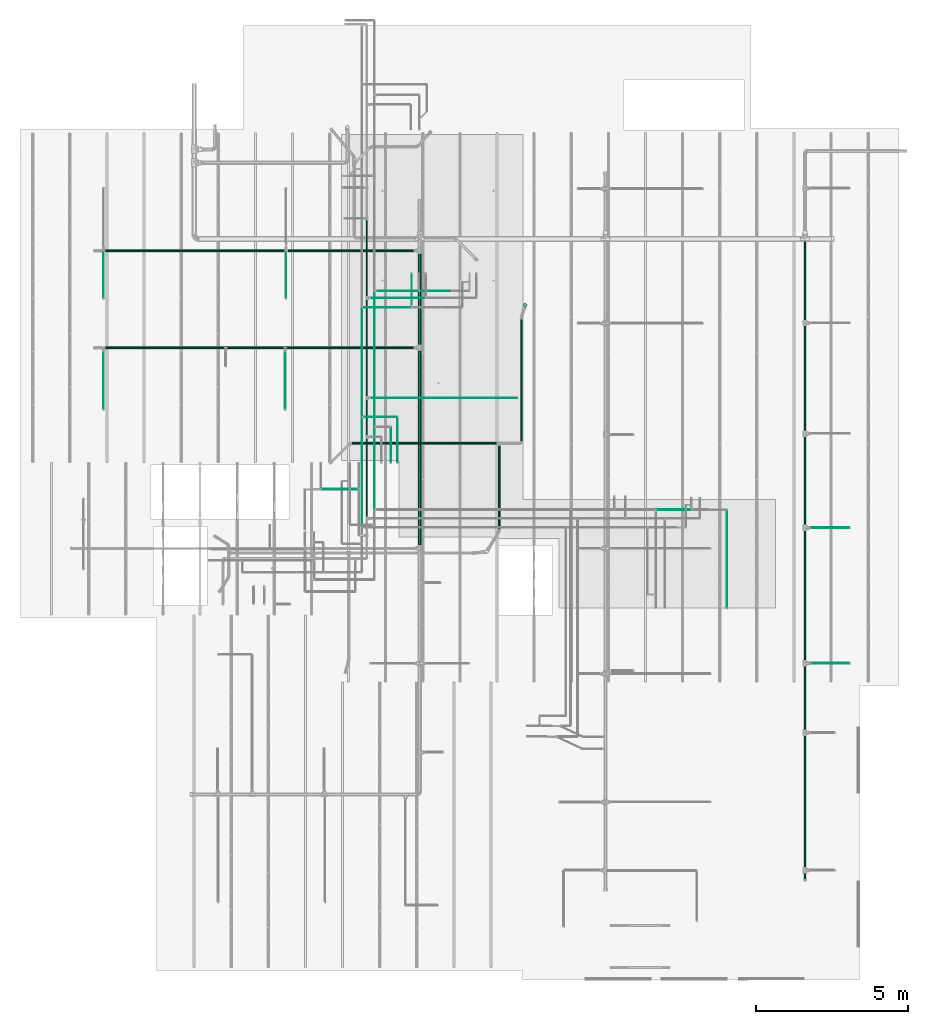
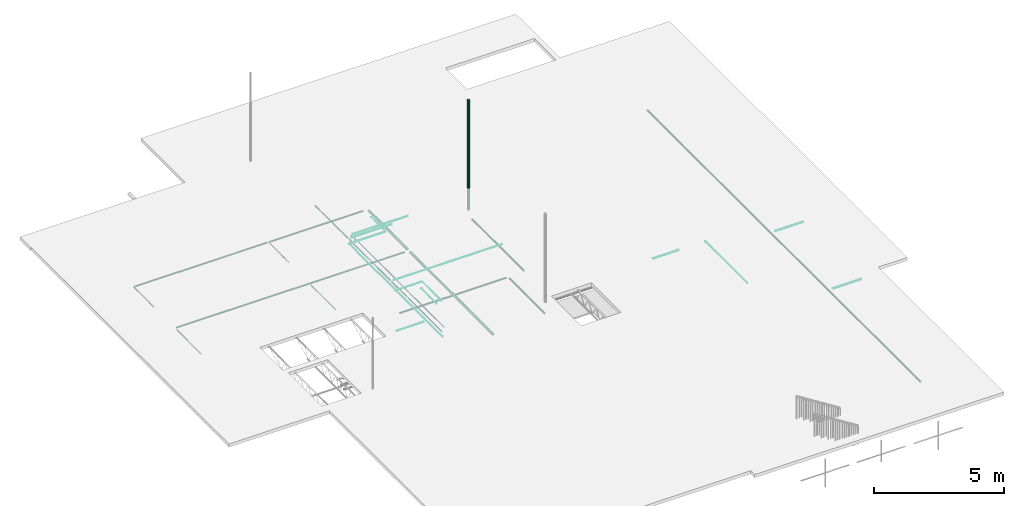
# One storey, part 5 of 173: 36 flow segments.
"""IFC2X3 building model written with IfcOpenShell, lengths in feet."""

from ifc_helpers import new_model, entity, si_unit, converted_unit, derived_unit, direction, frame, origin, origin_2d_with_axis, place, context, subcontext, project, spatial, circle, extrude, source, transform, mapped, type_object, type_shapes, element, save


model = new_model("IFC2X3")

# Units and contexts
model_context = context("Model", 3, precision=0.0001, world=origin(), true_north=direction((6.12303176911189e-17, 1.0)))
body_context = subcontext(model_context, "Body", "Model", "MODEL_VIEW")
ifc_project = project(units=[converted_unit("LENGTHUNIT", "FOOT", entity("IfcRatioMeasure", 0.3048), si_unit("LENGTHUNIT", "METRE"), dimensions=[1, 0, 0, 0, 0, 0, 0]), converted_unit("AREAUNIT", "SQUARE FOOT", entity("IfcRatioMeasure", 0.09290304), si_unit("AREAUNIT", "SQUARE_METRE"), dimensions=[2, 0, 0, 0, 0, 0, 0]), converted_unit("VOLUMEUNIT", "CUBIC FOOT", entity("IfcRatioMeasure", 0.028316846592), si_unit("VOLUMEUNIT", "CUBIC_METRE"), dimensions=[3, 0, 0, 0, 0, 0, 0]), converted_unit("PLANEANGLEUNIT", "DEGREE", entity("IfcRatioMeasure", 0.0174532925199433), si_unit("PLANEANGLEUNIT", "RADIAN"), dimensions=[0, 0, 0, 0, 0, 0, 0]), si_unit("MASSUNIT", "GRAM", prefix="KILO"), derived_unit("MASSDENSITYUNIT", [(si_unit("MASSUNIT", "GRAM", prefix="KILO"), 1), (si_unit("LENGTHUNIT", "METRE"), -3)]), si_unit("TIMEUNIT", "SECOND"), si_unit("FREQUENCYUNIT", "HERTZ"), si_unit("THERMODYNAMICTEMPERATUREUNIT", "DEGREE_CELSIUS"), derived_unit("THERMALTRANSMITTANCEUNIT", [(si_unit("MASSUNIT", "GRAM", prefix="KILO"), 1), (si_unit("THERMODYNAMICTEMPERATUREUNIT", "KELVIN"), -1), (si_unit("TIMEUNIT", "SECOND"), -3)]), derived_unit("VOLUMETRICFLOWRATEUNIT", [(si_unit("LENGTHUNIT", "METRE"), 3), (si_unit("TIMEUNIT", "SECOND"), -1)]), si_unit("ELECTRICCURRENTUNIT", "AMPERE"), si_unit("ELECTRICVOLTAGEUNIT", "VOLT"), si_unit("POWERUNIT", "WATT"), si_unit("FORCEUNIT", "NEWTON"), si_unit("ILLUMINANCEUNIT", "LUX"), si_unit("LUMINOUSFLUXUNIT", "LUMEN"), si_unit("LUMINOUSINTENSITYUNIT", "CANDELA"), derived_unit("USERDEFINED", [(si_unit("MASSUNIT", "GRAM", prefix="KILO"), -1), (si_unit("LENGTHUNIT", "METRE"), -2), (si_unit("TIMEUNIT", "SECOND"), 3), (si_unit("LUMINOUSFLUXUNIT", "LUMEN"), 1)]), derived_unit("LINEARVELOCITYUNIT", [(si_unit("LENGTHUNIT", "METRE"), 1), (si_unit("TIMEUNIT", "SECOND"), -1)]), si_unit("PRESSUREUNIT", "PASCAL"), derived_unit("USERDEFINED", [(si_unit("LENGTHUNIT", "METRE"), -2), (si_unit("MASSUNIT", "GRAM", prefix="KILO"), 1), (si_unit("TIMEUNIT", "SECOND"), -2)])], contexts=[model_context])

# Site, building, storey
site_placement = place(None, origin())
site = spatial("IfcSite", under=ifc_project, at=site_placement, CompositionType="ELEMENT")
building_placement = place(site_placement, origin())
building = spatial("IfcBuilding", under=site, at=building_placement, CompositionType="ELEMENT")
storey_placement = place(building_placement, frame((0.0, 0.0, 8.0)))
storey = spatial("IfcBuildingStorey", under=building, at=storey_placement, Name="REF", CompositionType="ELEMENT", Elevation=8.0)

# Flow segments
pipe_segment_type_1 = type_object("IfcPipeSegmentType", Name="Pipe Types:Standard", PredefinedType="NOTDEFINED")
shared_shape_1 = source(origin(), body_context, "Body", "SweptSolid", [
    extrude(circle(Radius=0.171875, at=origin_2d_with_axis()), frame((14.7453209336625, 35.3918659870249, 9.92847256397639)), (0.0, 0.0, 1.0), 16.9888451443569),
])
type_shapes(pipe_segment_type_1, [shared_shape_1])
flow_segment_1_placement = place(storey_placement, frame((0.0, 0.0, -8.0)))
element("IfcFlowSegment", 1, at=flow_segment_1_placement, inside=storey, type_object=pipe_segment_type_1, Name="Pipe Types:Standard:Standard : Pipe Types:Standard", ObjectType="Standard : Pipe Types:Standard", context=body_context, shape_type="MappedRepresentation", body=[
    mapped(shared_shape_1, transform((0.0, 0.0, 0.0), scale=1.0)),
])
pipe_segment_type_2 = type_object("IfcPipeSegmentType", Name="Pipe Types:Standard", PredefinedType="NOTDEFINED")
shared_shape_2 = source(origin(), body_context, "Body", "SweptSolid", [
    extrude(circle(Radius=0.130208333333333, at=origin_2d_with_axis()), frame((44.8963306532551, -26.4967650842793, 10.4173177083333), z_axis=(0.0, 1.0, 0.0), x_axis=(1.0, 0.0, 0.0)), (0.0, 0.0, 1.0), 69.0),
])
type_shapes(pipe_segment_type_2, [shared_shape_2])
flow_segment_2_placement = place(storey_placement, frame((0.0, 0.0, -8.0)))
element("IfcFlowSegment", 2, at=flow_segment_2_placement, inside=storey, type_object=pipe_segment_type_2, Name="Pipe Types:Standard:Standard : Pipe Types:Standard", ObjectType="Standard : Pipe Types:Standard", context=body_context, shape_type="MappedRepresentation", body=[
    mapped(shared_shape_2, transform((0.0, 0.0, 0.0), scale=1.0)),
])
pipe_segment_type_3 = type_object("IfcPipeSegmentType", Name="Pipe Types:Standard", PredefinedType="NOTDEFINED")
shared_shape_3 = source(origin(), body_context, "Body", "SweptSolid", [
    extrude(circle(Radius=0.171875, at=origin_2d_with_axis()), frame((3.39633065325509, 31.1275034224548, 10.4173177083333), z_axis=(0.0, 1.0, 0.0), x_axis=(1.0, 0.0, 0.0)), (0.0, 0.0, 1.0), 9.77310465993581),
])
type_shapes(pipe_segment_type_3, [shared_shape_3])
flow_segment_3_placement = place(storey_placement, frame((0.0, 0.0, -8.0)))
element("IfcFlowSegment", 3, at=flow_segment_3_placement, inside=storey, type_object=pipe_segment_type_3, Name="Pipe Types:Standard:Standard : Pipe Types:Standard", ObjectType="Standard : Pipe Types:Standard", context=body_context, shape_type="MappedRepresentation", body=[
    mapped(shared_shape_3, transform((0.0, 0.0, 0.0), scale=1.0)),
])
pipe_segment_type_4 = type_object("IfcPipeSegmentType", Name="Pipe Types:Standard", PredefinedType="NOTDEFINED")
shared_shape_4 = source(origin(), body_context, "Body", "SweptSolid", [
    extrude(circle(Radius=0.171875, at=origin_2d_with_axis()), frame((3.39633065325509, 9.51941246670513, 10.4173177083333), z_axis=(0.0, 1.0, 0.0), x_axis=(1.0, 0.0, 0.0)), (0.0, 0.0, 1.0), 20.9191145777969),
])
type_shapes(pipe_segment_type_4, [shared_shape_4])
flow_segment_4_placement = place(storey_placement, frame((0.0, 0.0, -8.0)))
element("IfcFlowSegment", 4, at=flow_segment_4_placement, inside=storey, type_object=pipe_segment_type_4, Name="Pipe Types:Standard:Standard : Pipe Types:Standard", ObjectType="Standard : Pipe Types:Standard", context=body_context, shape_type="MappedRepresentation", body=[
    mapped(shared_shape_4, transform((0.0, 0.0, 0.0), scale=1.0)),
])
pipe_segment_type_5 = type_object("IfcPipeSegmentType", Name="Pipe Types:Standard", PredefinedType="NOTDEFINED")
shared_shape_5 = source(origin(), body_context, "Body", "SweptSolid", [
    extrude(circle(Radius=0.0885416666666667, at=origin_2d_with_axis()), frame((-30.4718603108799, 41.245096271367, 10.4173177083333), z_axis=(1.0, 0.0, 0.0), x_axis=(0.0, 1.0, 0.0)), (0.0, 0.0, 1.0), 19.2467191601049),
])
type_shapes(pipe_segment_type_5, [shared_shape_5])
flow_segment_5_placement = place(storey_placement, frame((0.0, 0.0, -8.0)))
element("IfcFlowSegment", 5, at=flow_segment_5_placement, inside=storey, type_object=pipe_segment_type_5, Name="Pipe Types:Standard:Standard : Pipe Types:Standard", ObjectType="Standard : Pipe Types:Standard", context=body_context, shape_type="MappedRepresentation", body=[
    mapped(shared_shape_5, transform((0.0, 0.0, 0.0), scale=1.0)),
])
pipe_segment_type_6 = type_object("IfcPipeSegmentType", Name="Pipe Types:Standard", PredefinedType="NOTDEFINED")
shared_shape_6 = source(origin(), body_context, "Body", "SweptSolid", [
    extrude(circle(Radius=0.046875, at=origin_2d_with_axis()), frame((-30.6818340641608, 36.1604506020755, 10.4173177083333), z_axis=(0.0, 1.0, 0.0), x_axis=(-1.0, 0.0, 0.0)), (0.0, 0.0, 1.0), 5.08464566929136),
])
type_shapes(pipe_segment_type_6, [shared_shape_6])
flow_segment_6_placement = place(storey_placement, frame((0.0, 0.0, -8.0)))
element("IfcFlowSegment", 6, at=flow_segment_6_placement, inside=storey, type_object=pipe_segment_type_6, Name="Pipe Types:Standard:Standard : Pipe Types:Standard", ObjectType="Standard : Pipe Types:Standard", context=body_context, shape_type="MappedRepresentation", body=[
    mapped(shared_shape_6, transform((0.0, 0.0, 0.0), scale=1.0)),
])
pipe_segment_type_7 = type_object("IfcPipeSegmentType", Name="Pipe Types:Standard", PredefinedType="NOTDEFINED")
shared_shape_7 = source(origin(), body_context, "Body", "SweptSolid", [
    extrude(circle(Radius=0.0885416666666667, at=origin_2d_with_axis()), frame((-10.8051936442133, 41.245096271367, 10.4173177083333), z_axis=(1.0, 0.0, 0.0), x_axis=(0.0, 1.0, 0.0)), (0.0, 0.0, 1.0), 13.5223904392007),
])
type_shapes(pipe_segment_type_7, [shared_shape_7])
flow_segment_7_placement = place(storey_placement, frame((0.0, 0.0, -8.0)))
element("IfcFlowSegment", 7, at=flow_segment_7_placement, inside=storey, type_object=pipe_segment_type_7, Name="Pipe Types:Standard:Standard : Pipe Types:Standard", ObjectType="Standard : Pipe Types:Standard", context=body_context, shape_type="MappedRepresentation", body=[
    mapped(shared_shape_7, transform((0.0, 0.0, 0.0), scale=1.0)),
])
pipe_segment_type_8 = type_object("IfcPipeSegmentType", Name="Pipe Types:Standard", PredefinedType="NOTDEFINED")
shared_shape_8 = source(origin(), body_context, "Body", "SweptSolid", [
    extrude(circle(Radius=0.046875, at=origin_2d_with_axis()), frame((-11.0151673974942, 36.1604506020755, 10.4173177083333), z_axis=(0.0, 1.0, 0.0), x_axis=(-1.0, 0.0, 0.0)), (0.0, 0.0, 1.0), 5.08464566929136),
])
type_shapes(pipe_segment_type_8, [shared_shape_8])
flow_segment_8_placement = place(storey_placement, frame((0.0, 0.0, -8.0)))
element("IfcFlowSegment", 8, at=flow_segment_8_placement, inside=storey, type_object=pipe_segment_type_8, Name="Pipe Types:Standard:Standard : Pipe Types:Standard", ObjectType="Standard : Pipe Types:Standard", context=body_context, shape_type="MappedRepresentation", body=[
    mapped(shared_shape_8, transform((0.0, 0.0, 0.0), scale=1.0)),
])
pipe_segment_type_9 = type_object("IfcPipeSegmentType", Name="Pipe Types:Standard", PredefinedType="NOTDEFINED")
shared_shape_9 = source(origin(), body_context, "Body", "SweptSolid", [
    extrude(circle(Radius=0.046875, at=origin_2d_with_axis()), frame((-30.6818340641608, 24.1983695641872, 10.4173177083333), z_axis=(0.0, 1.0, 0.0), x_axis=(-1.0, 0.0, 0.0)), (0.0, 0.0, 1.0), 6.12532808398936),
])
type_shapes(pipe_segment_type_9, [shared_shape_9])
flow_segment_9_placement = place(storey_placement, frame((0.0, 0.0, -8.0)))
element("IfcFlowSegment", 9, at=flow_segment_9_placement, inside=storey, type_object=pipe_segment_type_9, Name="Pipe Types:Standard:Standard : Pipe Types:Standard", ObjectType="Standard : Pipe Types:Standard", context=body_context, shape_type="MappedRepresentation", body=[
    mapped(shared_shape_9, transform((0.0, 0.0, 0.0), scale=1.0)),
])
pipe_segment_type_10 = type_object("IfcPipeSegmentType", Name="Pipe Types:Standard", PredefinedType="NOTDEFINED")
shared_shape_10 = source(origin(), body_context, "Body", "SweptSolid", [
    extrude(circle(Radius=0.0885416666666667, at=origin_2d_with_axis()), frame((-30.47186031088, 30.7830152334784, 10.4173177083333), z_axis=(1.0, 0.0, 0.0), x_axis=(0.0, 1.0, 0.0)), (0.0, 0.0, 1.0), 33.1890571058673),
])
type_shapes(pipe_segment_type_10, [shared_shape_10])
flow_segment_10_placement = place(storey_placement, frame((0.0, 0.0, -8.0)))
element("IfcFlowSegment", 10, at=flow_segment_10_placement, inside=storey, type_object=pipe_segment_type_10, Name="Pipe Types:Standard:Standard : Pipe Types:Standard", ObjectType="Standard : Pipe Types:Standard", context=body_context, shape_type="MappedRepresentation", body=[
    mapped(shared_shape_10, transform((0.0, 0.0, 0.0), scale=1.0)),
])
pipe_segment_type_11 = type_object("IfcPipeSegmentType", Name="Pipe Types:Standard", PredefinedType="NOTDEFINED")
shared_shape_11 = source(origin(), body_context, "Body", "SweptSolid", [
    extrude(circle(Radius=0.046875, at=origin_2d_with_axis()), frame((-11.0985007308275, 24.1983695641871, 10.4173177083333), z_axis=(0.0, 1.0, 0.0), x_axis=(-1.0, 0.0, 0.0)), (0.0, 0.0, 1.0), 6.12532808398936),
])
type_shapes(pipe_segment_type_11, [shared_shape_11])
flow_segment_11_placement = place(storey_placement, frame((0.0, 0.0, -8.0)))
element("IfcFlowSegment", 11, at=flow_segment_11_placement, inside=storey, type_object=pipe_segment_type_11, Name="Pipe Types:Standard:Standard : Pipe Types:Standard", ObjectType="Standard : Pipe Types:Standard", context=body_context, shape_type="MappedRepresentation", body=[
    mapped(shared_shape_11, transform((0.0, 0.0, 0.0), scale=1.0)),
])
pipe_segment_type_12 = type_object("IfcPipeSegmentType", Name="Pipe Types:Standard", PredefinedType="NOTDEFINED")
shared_shape_12 = source(origin(), body_context, "Body", "SweptSolid", [
    extrude(circle(Radius=0.046875, at=origin_2d_with_axis()), frame((45.5754645115229, 11.3758538235385, 10.4173177083333), z_axis=(1.0, 0.0, 0.0), x_axis=(0.0, -1.0, 0.0)), (0.0, 0.0, 1.0), 4.07217847769013),
])
type_shapes(pipe_segment_type_12, [shared_shape_12])
flow_segment_12_placement = place(storey_placement, frame((0.0, 0.0, -8.0)))
element("IfcFlowSegment", 12, at=flow_segment_12_placement, inside=storey, type_object=pipe_segment_type_12, Name="Pipe Types:Standard:Standard : Pipe Types:Standard", ObjectType="Standard : Pipe Types:Standard", context=body_context, shape_type="MappedRepresentation", body=[
    mapped(shared_shape_12, transform((0.0, 0.0, 0.0), scale=1.0)),
])
pipe_segment_type_13 = type_object("IfcPipeSegmentType", Name="Pipe Types:Standard", PredefinedType="NOTDEFINED")
shared_shape_13 = source(origin(), body_context, "Body", "SweptSolid", [
    extrude(circle(Radius=0.046875, at=origin_2d_with_axis()), frame((45.5754645115229, -3.20747950979483, 10.4173177083333), z_axis=(1.0, 0.0, 0.0), x_axis=(0.0, -1.0, 0.0)), (0.0, 0.0, 1.0), 4.07217847769013),
])
type_shapes(pipe_segment_type_13, [shared_shape_13])
flow_segment_13_placement = place(storey_placement, frame((0.0, 0.0, -8.0)))
element("IfcFlowSegment", 13, at=flow_segment_13_placement, inside=storey, type_object=pipe_segment_type_13, Name="Pipe Types:Standard:Standard : Pipe Types:Standard", ObjectType="Standard : Pipe Types:Standard", context=body_context, shape_type="MappedRepresentation", body=[
    mapped(shared_shape_13, transform((0.0, 0.0, 0.0), scale=1.0)),
])
pipe_segment_type_14 = type_object("IfcPipeSegmentType", Name="Pipe Types:Standard", PredefinedType="NOTDEFINED")
shared_shape_14 = source(origin(), body_context, "Body", "SweptSolid", [
    extrude(circle(Radius=0.0364583333333333, at=origin_2d_with_axis()), frame((-7.15993743672555, 15.5374164738886, 11.0), z_axis=(1.0, 0.0, 0.0), x_axis=(0.0, 1.0, 0.0)), (0.0, 0.0, 1.0), 3.91914996984618),
])
type_shapes(pipe_segment_type_14, [shared_shape_14])
flow_segment_14_placement = place(storey_placement, frame((0.0, 0.0, -8.0)))
element("IfcFlowSegment", 14, at=flow_segment_14_placement, inside=storey, type_object=pipe_segment_type_14, Name="Pipe Types:Standard:Standard : Pipe Types:Standard", ObjectType="Standard : Pipe Types:Standard", context=body_context, shape_type="MappedRepresentation", body=[
    mapped(shared_shape_14, transform((0.0, 0.0, 0.0), scale=1.0)),
])
pipe_segment_type_15 = type_object("IfcPipeSegmentType", Name="Pipe Types:Standard", PredefinedType="NOTDEFINED")
shared_shape_15 = source(origin(), body_context, "Body", "SweptSolid", [
    extrude(circle(Radius=0.0677083333333333, at=origin_2d_with_axis()), frame((-2.31230977659057, 12.5635835333277, 11.0), z_axis=(0.0, 1.0, 0.0), x_axis=(1.0, 0.0, 0.0)), (0.0, 0.0, 1.0), 8.43205283946716),
])
type_shapes(pipe_segment_type_15, [shared_shape_15])
flow_segment_15_placement = place(storey_placement, frame((0.0, 0.0, -8.0)))
element("IfcFlowSegment", 15, at=flow_segment_15_placement, inside=storey, type_object=pipe_segment_type_15, Name="Pipe Types:Standard:Standard : Pipe Types:Standard", ObjectType="Standard : Pipe Types:Standard", context=body_context, shape_type="MappedRepresentation", body=[
    mapped(shared_shape_15, transform((0.0, 0.0, 0.0), scale=1.0)),
])
pipe_segment_type_16 = type_object("IfcPipeSegmentType", Name="Pipe Types:Standard", PredefinedType="NOTDEFINED")
shared_shape_16 = source(origin(), body_context, "Body", "SweptSolid", [
    extrude(circle(Radius=0.0677083333333333, at=origin_2d_with_axis()), frame((-2.31230977659055, 25.5681874248572, 11.0), z_axis=(0.0, 1.0, 0.0), x_axis=(1.0, 0.0, 0.0)), (0.0, 0.0, 1.0), 10.4001314068092),
])
type_shapes(pipe_segment_type_16, [shared_shape_16])
flow_segment_16_placement = place(storey_placement, frame((0.0, 0.0, -8.0)))
element("IfcFlowSegment", 16, at=flow_segment_16_placement, inside=storey, type_object=pipe_segment_type_16, Name="Pipe Types:Standard:Standard : Pipe Types:Standard", ObjectType="Standard : Pipe Types:Standard", context=body_context, shape_type="MappedRepresentation", body=[
    mapped(shared_shape_16, transform((0.0, 0.0, 0.0), scale=1.0)),
])
pipe_segment_type_17 = type_object("IfcPipeSegmentType", Name="Pipe Types:Standard", PredefinedType="NOTDEFINED")
shared_shape_17 = source(origin(), body_context, "Body", "SweptSolid", [
    extrude(circle(Radius=0.0364583333333333, at=origin_2d_with_axis()), frame((-1.91532814929394, 36.1553267056821, 11.0), z_axis=(1.0, 0.0, 0.0), x_axis=(0.0, -1.0, 0.0)), (0.0, 0.0, 1.0), 5.86980886909161),
])
type_shapes(pipe_segment_type_17, [shared_shape_17])
flow_segment_17_placement = place(storey_placement, frame((0.0, 0.0, -8.0)))
element("IfcFlowSegment", 17, at=flow_segment_17_placement, inside=storey, type_object=pipe_segment_type_17, Name="Pipe Types:Standard:Standard : Pipe Types:Standard", ObjectType="Standard : Pipe Types:Standard", context=body_context, shape_type="MappedRepresentation", body=[
    mapped(shared_shape_17, transform((0.0, 0.0, 0.0), scale=1.0)),
])
pipe_segment_type_18 = type_object("IfcPipeSegmentType", Name="Pipe Types:Standard", PredefinedType="NOTDEFINED")
shared_shape_18 = source(origin(), body_context, "Body", "SweptSolid", [
    extrude(circle(Radius=0.0677083333333333, at=origin_2d_with_axis()), frame((-2.31230977659058, 36.3423345796979, 11.0), z_axis=(0.0, 1.0, 0.0), x_axis=(1.0, 0.0, 0.0)), (0.0, 0.0, 1.0), 8.19592421291796),
])
type_shapes(pipe_segment_type_18, [shared_shape_18])
flow_segment_18_placement = place(storey_placement, frame((0.0, 0.0, -8.0)))
element("IfcFlowSegment", 18, at=flow_segment_18_placement, inside=storey, type_object=pipe_segment_type_18, Name="Pipe Types:Standard:Standard : Pipe Types:Standard", ObjectType="Standard : Pipe Types:Standard", context=body_context, shape_type="MappedRepresentation", body=[
    mapped(shared_shape_18, transform((0.0, 0.0, 0.0), scale=1.0)),
])
pipe_segment_type_19 = type_object("IfcPipeSegmentType", Name="Pipe Types:Standard", PredefinedType="NOTDEFINED")
shared_shape_19 = source(origin(), body_context, "Body", "SweptSolid", [
    extrude(circle(Radius=0.046875, at=origin_2d_with_axis()), frame((-1.47897644325719, 13.4554452073789, 10.8333333333333), z_axis=(0.0, 1.0, 0.0), x_axis=(-1.0, 0.0, 0.0)), (0.0, 0.0, 1.0), 8.68947368438995),
])
type_shapes(pipe_segment_type_19, [shared_shape_19])
flow_segment_19_placement = place(storey_placement, frame((0.0, 0.0, -8.0)))
element("IfcFlowSegment", 19, at=flow_segment_19_placement, inside=storey, type_object=pipe_segment_type_19, Name="Pipe Types:Standard:Standard : Pipe Types:Standard", ObjectType="Standard : Pipe Types:Standard", context=body_context, shape_type="MappedRepresentation", body=[
    mapped(shared_shape_19, transform((0.0, 0.0, 0.0), scale=1.0)),
])
pipe_segment_type_20 = type_object("IfcPipeSegmentType", Name="Pipe Types:Standard", PredefinedType="NOTDEFINED")
shared_shape_20 = source(origin(), body_context, "Body", "SweptSolid", [
    extrude(circle(Radius=0.0260416666666667, at=origin_2d_with_axis()), frame((36.5210235567427, 2.74888042972497, 10.8333333333333), z_axis=(0.0, 1.0, 0.0), x_axis=(-1.0, 0.0, 0.0)), (0.0, 0.0, 1.0), 10.5335530178933),
])
type_shapes(pipe_segment_type_20, [shared_shape_20])
flow_segment_20_placement = place(storey_placement, frame((0.0, 0.0, -8.0)))
element("IfcFlowSegment", 20, at=flow_segment_20_placement, inside=storey, type_object=pipe_segment_type_20, Name="Pipe Types:Standard:Standard : Pipe Types:Standard", ObjectType="Standard : Pipe Types:Standard", context=body_context, shape_type="MappedRepresentation", body=[
    mapped(shared_shape_20, transform((0.0, 0.0, 0.0), scale=1.0)),
])
pipe_segment_type_21 = type_object("IfcPipeSegmentType", Name="Pipe Types:Standard", PredefinedType="NOTDEFINED")
shared_shape_21 = source(origin(), body_context, "Body", "SweptSolid", [
    extrude(circle(Radius=0.0364583333333333, at=origin_2d_with_axis()), frame((28.9176989056042, 13.3307732913684, 10.8333333333333), z_axis=(1.0, 0.0, 0.0), x_axis=(0.0, -1.0, 0.0)), (0.0, 0.0, 1.0), 3.67594829190856),
])
type_shapes(pipe_segment_type_21, [shared_shape_21])
flow_segment_21_placement = place(storey_placement, frame((0.0, 0.0, -8.0)))
element("IfcFlowSegment", 21, at=flow_segment_21_placement, inside=storey, type_object=pipe_segment_type_21, Name="Pipe Types:Standard:Standard : Pipe Types:Standard", ObjectType="Standard : Pipe Types:Standard", context=body_context, shape_type="MappedRepresentation", body=[
    mapped(shared_shape_21, transform((0.0, 0.0, 0.0), scale=1.0)),
])
pipe_segment_type_22 = type_object("IfcPipeSegmentType", Name="Pipe Types:Standard", PredefinedType="NOTDEFINED")
shared_shape_22 = source(origin(), body_context, "Body", "SweptSolid", [
    extrude(circle(Radius=0.0260416666666667, at=origin_2d_with_axis()), frame((0.271023556742803, 18.4256309149522, 10.8333333333333), z_axis=(0.0, 1.0, 0.0), x_axis=(-1.0, 0.0, 0.0)), (0.0, 0.0, 1.0), 3.79562004907715),
])
type_shapes(pipe_segment_type_22, [shared_shape_22])
flow_segment_22_placement = place(storey_placement, frame((0.0, 0.0, -8.0)))
element("IfcFlowSegment", 22, at=flow_segment_22_placement, inside=storey, type_object=pipe_segment_type_22, Name="Pipe Types:Standard:Standard : Pipe Types:Standard", ObjectType="Standard : Pipe Types:Standard", context=body_context, shape_type="MappedRepresentation", body=[
    mapped(shared_shape_22, transform((0.0, 0.0, 0.0), scale=1.0)),
])
pipe_segment_type_23 = type_object("IfcPipeSegmentType", Name="Pipe Types:Standard", PredefinedType="NOTDEFINED")
shared_shape_23 = source(origin(), body_context, "Body", "SweptSolid", [
    extrude(circle(Radius=0.0364583333333333, at=origin_2d_with_axis()), frame((3.41555715819724, 36.9188038218153, 10.8333333333333), z_axis=(1.0, 0.0, 0.0), x_axis=(0.0, -1.0, 0.0)), (0.0, 0.0, 1.0), 3.35546639854555),
])
type_shapes(pipe_segment_type_23, [shared_shape_23])
flow_segment_23_placement = place(storey_placement, frame((0.0, 0.0, -8.0)))
element("IfcFlowSegment", 23, at=flow_segment_23_placement, inside=storey, type_object=pipe_segment_type_23, Name="Pipe Types:Standard:Standard : Pipe Types:Standard", ObjectType="Standard : Pipe Types:Standard", context=body_context, shape_type="MappedRepresentation", body=[
    mapped(shared_shape_23, transform((0.0, 0.0, 0.0), scale=1.0)),
])
pipe_segment_type_24 = type_object("IfcPipeSegmentType", Name="Pipe Types:Standard", PredefinedType="NOTDEFINED")
shared_shape_24 = source(origin(), body_context, "Body", "SweptSolid", [
    extrude(circle(Radius=0.046875, at=origin_2d_with_axis()), frame((-1.47897644325719, 22.3942627237898, 10.8333333333333), z_axis=(0.0, 1.0, 0.0), x_axis=(-1.0, 0.0, 0.0)), (0.0, 0.0, 1.0), 14.399869182015),
])
type_shapes(pipe_segment_type_24, [shared_shape_24])
flow_segment_24_placement = place(storey_placement, frame((0.0, 0.0, -8.0)))
element("IfcFlowSegment", 24, at=flow_segment_24_placement, inside=storey, type_object=pipe_segment_type_24, Name="Pipe Types:Standard:Standard : Pipe Types:Standard", ObjectType="Standard : Pipe Types:Standard", context=body_context, shape_type="MappedRepresentation", body=[
    mapped(shared_shape_24, transform((0.0, 0.0, 0.0), scale=1.0)),
])
pipe_segment_type_25 = type_object("IfcPipeSegmentType", Name="Pipe Types:Standard", PredefinedType="NOTDEFINED")
shared_shape_25 = source(origin(), body_context, "Body", "SweptSolid", [
    extrude(circle(Radius=0.0364583333333333, at=origin_2d_with_axis()), frame((-1.186981692601, 36.9188038218152, 10.8333333333334), z_axis=(1.0, 0.0, 0.0), x_axis=(0.0, -1.0, 0.0)), (0.0, 0.0, 1.0), 4.4122501368875),
])
type_shapes(pipe_segment_type_25, [shared_shape_25])
flow_segment_25_placement = place(storey_placement, frame((0.0, 0.0, -8.0)))
element("IfcFlowSegment", 25, at=flow_segment_25_placement, inside=storey, type_object=pipe_segment_type_25, Name="Pipe Types:Standard:Standard : Pipe Types:Standard", ObjectType="Standard : Pipe Types:Standard", context=body_context, shape_type="MappedRepresentation", body=[
    mapped(shared_shape_25, transform((0.0, 0.0, 0.0), scale=1.0)),
])
pipe_segment_type_26 = type_object("IfcPipeSegmentType", Name="Pipe Types:Standard", PredefinedType="NOTDEFINED")
shared_shape_26 = source(origin(), body_context, "Body", "SweptSolid", [
    extrude(circle(Radius=0.0364583333333333, at=origin_2d_with_axis()), frame((-2.82504298847781, 11.5267428902465, 11.0), z_axis=(0.0, 1.0, 0.0), x_axis=(-1.0, 0.0, 0.0)), (0.0, 0.0, 1.0), 11.6818327242293),
])
type_shapes(pipe_segment_type_26, [shared_shape_26])
flow_segment_26_placement = place(storey_placement, frame((0.0, 0.0, -8.0)))
element("IfcFlowSegment", 26, at=flow_segment_26_placement, inside=storey, type_object=pipe_segment_type_26, Name="Pipe Types:Standard:Standard : Pipe Types:Standard", ObjectType="Standard : Pipe Types:Standard", context=body_context, shape_type="MappedRepresentation", body=[
    mapped(shared_shape_26, transform((0.0, 0.0, 0.0), scale=1.0)),
])
pipe_segment_type_27 = type_object("IfcPipeSegmentType", Name="Pipe Types:Standard", PredefinedType="NOTDEFINED")
shared_shape_27 = source(origin(), body_context, "Body", "SweptSolid", [
    extrude(circle(Radius=0.0260416666666667, at=origin_2d_with_axis()), frame((-2.60522671551191, 23.3037199714311, 11.0), z_axis=(1.0, 0.0, 0.0), x_axis=(0.0, -1.0, 0.0)), (0.0, 0.0, 1.0), 3.56517721661744),
])
type_shapes(pipe_segment_type_27, [shared_shape_27])
flow_segment_27_placement = place(storey_placement, frame((0.0, 0.0, -8.0)))
element("IfcFlowSegment", 27, at=flow_segment_27_placement, inside=storey, type_object=pipe_segment_type_27, Name="Pipe Types:Standard:Standard : Pipe Types:Standard", ObjectType="Standard : Pipe Types:Standard", context=body_context, shape_type="MappedRepresentation", body=[
    mapped(shared_shape_27, transform((0.0, 0.0, 0.0), scale=1.0)),
])
pipe_segment_type_28 = type_object("IfcPipeSegmentType", Name="Pipe Types:Standard", PredefinedType="NOTDEFINED")
shared_shape_28 = source(origin(), body_context, "Body", "SweptSolid", [
    extrude(circle(Radius=0.0364583333333333, at=origin_2d_with_axis()), frame((-2.82504298847781, 23.3988643283865, 11.0), z_axis=(0.0, 1.0, 0.0), x_axis=(-1.0, 0.0, 0.0)), (0.0, 0.0, 1.0), 11.6447060263803),
])
type_shapes(pipe_segment_type_28, [shared_shape_28])
flow_segment_28_placement = place(storey_placement, frame((0.0, 0.0, -8.0)))
element("IfcFlowSegment", 28, at=flow_segment_28_placement, inside=storey, type_object=pipe_segment_type_28, Name="Pipe Types:Standard:Standard : Pipe Types:Standard", ObjectType="Standard : Pipe Types:Standard", context=body_context, shape_type="MappedRepresentation", body=[
    mapped(shared_shape_28, transform((0.0, 0.0, 0.0), scale=1.0)),
])
pipe_segment_type_29 = type_object("IfcPipeSegmentType", Name="Pipe Types:Standard", PredefinedType="NOTDEFINED")
shared_shape_29 = source(origin(), body_context, "Body", "SweptSolid", [
    extrude(circle(Radius=0.0260416666666667, at=origin_2d_with_axis()), frame((1.00829034485551, 18.4353931485145, 11.0), z_axis=(0.0, 1.0, 0.0), x_axis=(-1.0, 0.0, 0.0)), (0.0, 0.0, 1.0), 4.81998697916672),
])
type_shapes(pipe_segment_type_29, [shared_shape_29])
flow_segment_29_placement = place(storey_placement, frame((0.0, 0.0, -8.0)))
element("IfcFlowSegment", 29, at=flow_segment_29_placement, inside=storey, type_object=pipe_segment_type_29, Name="Pipe Types:Standard:Standard : Pipe Types:Standard", ObjectType="Standard : Pipe Types:Standard", context=body_context, shape_type="MappedRepresentation", body=[
    mapped(shared_shape_29, transform((0.0, 0.0, 0.0), scale=1.0)),
])
pipe_segment_type_30 = type_object("IfcPipeSegmentType", Name="Pipe Types:Standard", PredefinedType="NOTDEFINED")
shared_shape_30 = source(origin(), body_context, "Body", "SweptSolid", [
    extrude(circle(Radius=0.0364583333333333, at=origin_2d_with_axis()), frame((-2.72989863152243, 35.1387147117222, 11.0), z_axis=(1.0, 0.0, 0.0), x_axis=(0.0, -1.0, 0.0)), (0.0, 0.0, 1.0), 5.16239665555233),
])
type_shapes(pipe_segment_type_30, [shared_shape_30])
flow_segment_30_placement = place(storey_placement, frame((0.0, 0.0, -8.0)))
element("IfcFlowSegment", 30, at=flow_segment_30_placement, inside=storey, type_object=pipe_segment_type_30, Name="Pipe Types:Standard:Standard : Pipe Types:Standard", ObjectType="Standard : Pipe Types:Standard", context=body_context, shape_type="MappedRepresentation", body=[
    mapped(shared_shape_30, transform((0.0, 0.0, 0.0), scale=1.0)),
])
pipe_segment_type_31 = type_object("IfcPipeSegmentType", Name="Pipe Types:Standard", PredefinedType="NOTDEFINED")
shared_shape_31 = source(origin(), body_context, "Body", "SweptSolid", [
    extrude(circle(Radius=0.0260416666666667, at=origin_2d_with_axis()), frame((2.52764238098529, 35.3585309846881, 11.0), z_axis=(0.0, 1.0, 0.0), x_axis=(1.0, 0.0, 0.0)), (0.0, 0.0, 1.0), 3.4151225439108),
])
type_shapes(pipe_segment_type_31, [shared_shape_31])
flow_segment_31_placement = place(storey_placement, frame((0.0, 0.0, -8.0)))
element("IfcFlowSegment", 31, at=flow_segment_31_placement, inside=storey, type_object=pipe_segment_type_31, Name="Pipe Types:Standard:Standard : Pipe Types:Standard", ObjectType="Standard : Pipe Types:Standard", context=body_context, shape_type="MappedRepresentation", body=[
    mapped(shared_shape_31, transform((0.0, 0.0, 0.0), scale=1.0)),
])
pipe_segment_type_32 = type_object("IfcPipeSegmentType", Name="Pipe Types:Standard", PredefinedType="NOTDEFINED")
shared_shape_32 = source(origin(), body_context, "Body", "SweptSolid", [
    extrude(circle(Radius=0.0677083333333333, at=origin_2d_with_axis()), frame((-2.31230977659055, 21.3696521208263, 11.0), z_axis=(0.0, 1.0, 0.0), x_axis=(1.0, 0.0, 0.0)), (0.0, 0.0, 1.0), 3.82451955599938),
])
type_shapes(pipe_segment_type_32, [shared_shape_32])
flow_segment_32_placement = place(storey_placement, frame((0.0, 0.0, -8.0)))
element("IfcFlowSegment", 32, at=flow_segment_32_placement, inside=storey, type_object=pipe_segment_type_32, Name="Pipe Types:Standard:Standard : Pipe Types:Standard", ObjectType="Standard : Pipe Types:Standard", context=body_context, shape_type="MappedRepresentation", body=[
    mapped(shared_shape_32, transform((0.0, 0.0, 0.0), scale=1.0)),
])
pipe_segment_type_33 = type_object("IfcPipeSegmentType", Name="Pipe Types:Standard", PredefinedType="NOTDEFINED")
shared_shape_33 = source(origin(), body_context, "Body", "SweptSolid", [
    extrude(circle(Radius=0.0260416666666667, at=origin_2d_with_axis()), frame((-1.91532814929394, 25.3811795508414, 11.0), z_axis=(1.0, 0.0, 0.0), x_axis=(0.0, -1.0, 0.0)), (0.0, 0.0, 1.0), 15.8046785289534),
])
type_shapes(pipe_segment_type_33, [shared_shape_33])
flow_segment_33_placement = place(storey_placement, frame((0.0, 0.0, -8.0)))
element("IfcFlowSegment", 33, at=flow_segment_33_placement, inside=storey, type_object=pipe_segment_type_33, Name="Pipe Types:Standard:Standard : Pipe Types:Standard", ObjectType="Standard : Pipe Types:Standard", context=body_context, shape_type="MappedRepresentation", body=[
    mapped(shared_shape_33, transform((0.0, 0.0, 0.0), scale=1.0)),
])
pipe_segment_type_34 = type_object("IfcPipeSegmentType", Name="Pipe Types:Standard", PredefinedType="NOTDEFINED")
shared_shape_34 = source(origin(), body_context, "Body", "SweptSolid", [
    extrude(circle(Radius=0.130208333333333, at=origin_2d_with_axis()), frame((14.3543568900761, 20.7305393211984, 9.58398437499999), z_axis=(0.0, 1.0, 0.0), x_axis=(1.0, 0.0, 0.0)), (0.0, 0.0, 1.0), 13.0846456692913),
])
type_shapes(pipe_segment_type_34, [shared_shape_34])
flow_segment_34_placement = place(storey_placement, frame((0.0, 0.0, -8.0)))
element("IfcFlowSegment", 34, at=flow_segment_34_placement, inside=storey, type_object=pipe_segment_type_34, Name="Pipe Types:Standard:Standard : Pipe Types:Standard", ObjectType="Standard : Pipe Types:Standard", context=body_context, shape_type="MappedRepresentation", body=[
    mapped(shared_shape_34, transform((0.0, 0.0, 0.0), scale=1.0)),
])
pipe_segment_type_35 = type_object("IfcPipeSegmentType", Name="Pipe Types:Standard", PredefinedType="NOTDEFINED")
shared_shape_35 = source(origin(), body_context, "Body", "SweptSolid", [
    extrude(circle(Radius=0.130208333333333, at=origin_2d_with_axis()), frame((11.9376009680074, 11.2519921233894, 9.583984375), z_axis=(0.0, 1.0, 0.0), x_axis=(-1.0, 0.0, 0.0)), (0.0, 0.0, 1.0), 8.94705113481684),
])
type_shapes(pipe_segment_type_35, [shared_shape_35])
flow_segment_35_placement = place(storey_placement, frame((0.0, 0.0, -8.0)))
element("IfcFlowSegment", 35, at=flow_segment_35_placement, inside=storey, type_object=pipe_segment_type_35, Name="Pipe Types:Standard:Standard : Pipe Types:Standard", ObjectType="Standard : Pipe Types:Standard", context=body_context, shape_type="MappedRepresentation", body=[
    mapped(shared_shape_35, transform((0.0, 0.0, 0.0), scale=1.0)),
])
pipe_segment_type_36 = type_object("IfcPipeSegmentType", Name="Pipe Types:Standard", PredefinedType="NOTDEFINED")
shared_shape_36 = source(origin(), body_context, "Body", "SweptSolid", [
    extrude(circle(Radius=0.130208333333333, at=origin_2d_with_axis()), frame((-3.89629927790301, 20.4811954891774, 9.58398437499999), z_axis=(1.0, 0.0, 0.0), x_axis=(0.0, -1.0, 0.0)), (0.0, 0.0, 1.0), 15.5517480149393),
])
type_shapes(pipe_segment_type_36, [shared_shape_36])
flow_segment_36_placement = place(storey_placement, frame((0.0, 0.0, -8.0)))
element("IfcFlowSegment", 36, at=flow_segment_36_placement, inside=storey, type_object=pipe_segment_type_36, Name="Pipe Types:Standard:Standard : Pipe Types:Standard", ObjectType="Standard : Pipe Types:Standard", context=body_context, shape_type="MappedRepresentation", body=[
    mapped(shared_shape_36, transform((0.0, 0.0, 0.0), scale=1.0)),
])

save(model, "model.ifc")
